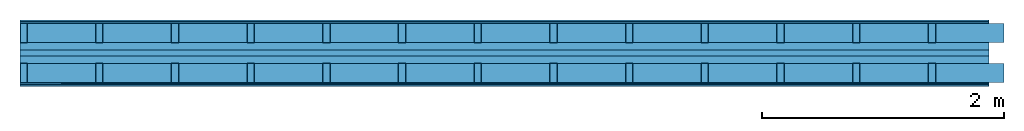
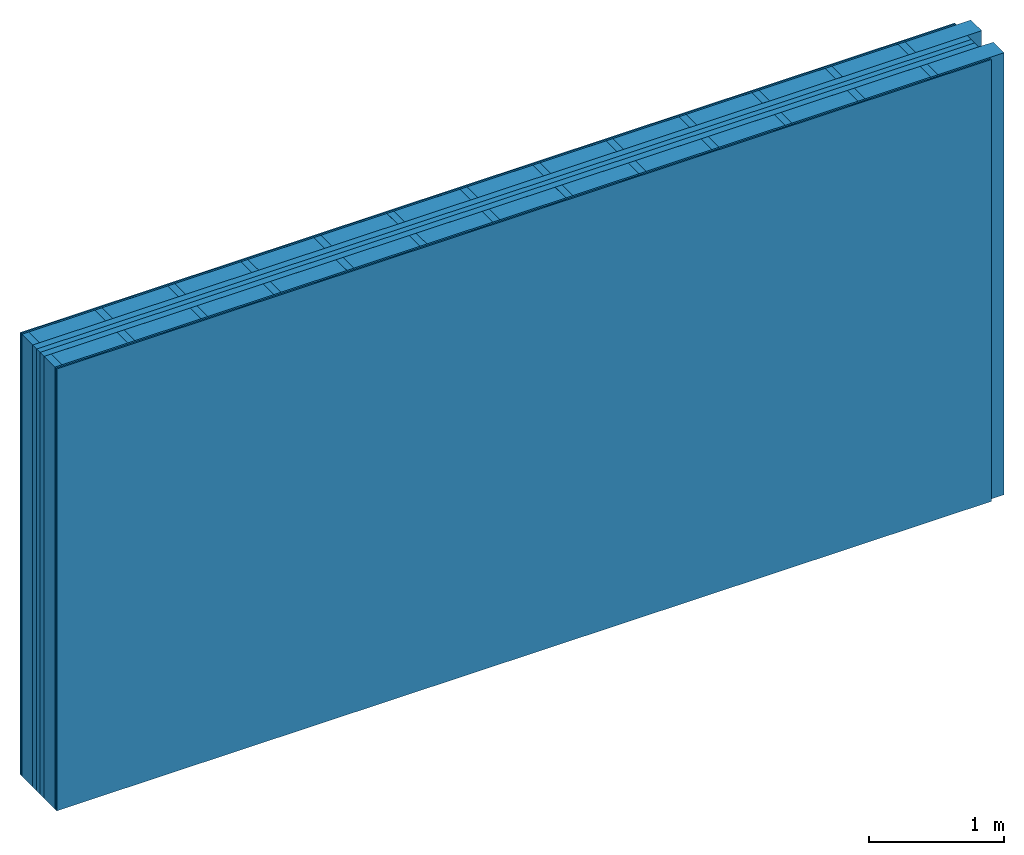
# One storey: 7 plates, 4 members, 1 element without a shape of its own.
"""IFC4 building model written with IfcOpenShell, lengths in metres."""

from ifc_helpers import new_model, si_unit, derived_unit, direction, frame, frame_2d, origin, origin_with_axes, place, context, project, spatial, rectangle, extrude, material, layer, layer_set, type_object, element, aggregate, save


model = new_model("IFC4")

# Units and contexts
plan_context = context("Plan", 3, precision=1e-05, world=origin(), true_north=direction((0.0, 1.0)))
model_context = context("Model", 3, precision=1e-05, world=origin(), true_north=direction((0.0, 1.0)))
ifc_project = project(units=[si_unit("LENGTHUNIT", "METRE"), derived_unit("SOUNDPRESSUREUNIT", [(si_unit("PRESSUREUNIT", "PASCAL", prefix="MICRO"), 0)]), si_unit("ENERGYUNIT", "JOULE", prefix="MEGA"), si_unit("MASSUNIT", "GRAM", prefix="KILO"), derived_unit("THERMALTRANSMITTANCEUNIT", [(si_unit("POWERUNIT", "WATT"), 1), (si_unit("AREAUNIT", "SQUARE_METRE"), -1), (si_unit("THERMODYNAMICTEMPERATUREUNIT", "KELVIN"), -1)]), derived_unit("AREADENSITYUNIT", [(si_unit("MASSUNIT", "GRAM", prefix="KILO"), 1), (si_unit("AREAUNIT", "SQUARE_METRE"), -1)]), derived_unit("USERDEFINED", [(si_unit("ENERGYUNIT", "JOULE", prefix="MEGA"), 1), (si_unit("AREAUNIT", "SQUARE_METRE"), -1)])], contexts=[plan_context, model_context])

# Site, building, storey
site = spatial("IfcSite", under=ifc_project)
building_placement = place(None, origin())
building = spatial("IfcBuilding", under=site, at=building_placement)
storey_placement = place(building_placement, origin())
storey = spatial("IfcBuildingStorey", under=building, at=storey_placement)

# Wall, members, plates
ifc_material_1 = material(Name="Glued joints")
ifc_layer_1 = layer(ifc_material_1, 0.0, Name="Surface")
ifc_material_2 = material(Category="03.007")
ifc_layer_2 = layer(ifc_material_2, 0.0125, Name="room side 2nd layer")
ifc_material_3 = material(Name="OSB/3", Category="07.013")
ifc_layer_3 = layer(ifc_material_3, 0.015, Name="room side 1st layer")
ifc_layer_4 = layer(None, 0.16, Name="Support")
ifc_material_4 = material(Name="of the art")
ifc_layer_5 = layer(ifc_material_4, 0.0, Name="Bond")
ifc_material_5 = material(Category="10.009")
ifc_layer_6 = layer(ifc_material_5, 0.06, Name="outside 1st layer")
ifc_material_6 = material(Name="Air")
ifc_layer_7 = layer(ifc_material_6, 0.05, Name="Air gap")
ifc_layer_8 = layer(ifc_material_5, 0.06, Name="outside 1st layer")
ifc_layer_9 = layer(ifc_material_4, 0.0, Name="Bond")
ifc_layer_10 = layer(None, 0.16, Name="Support")
ifc_layer_11 = layer(ifc_material_3, 0.015, Name="room side 1st layer")
ifc_layer_12 = layer(ifc_material_2, 0.0125, Name="room side 2nd layer")
ifc_layer_set = layer_set([ifc_layer_1, ifc_layer_2, ifc_layer_3, ifc_layer_4, ifc_layer_5, ifc_layer_6, ifc_layer_7, ifc_layer_8, ifc_layer_9, ifc_layer_10, ifc_layer_11, ifc_layer_12])
wall_type = type_object("IfcWallType", Name="B9398", PredefinedType="NOTDEFINED", material=ifc_layer_set)
wall_placement = place(None, frame((0.0, 0.0, 0.0), z_axis=(0.0, -1.0, 0.0), x_axis=(1.0, 0.0, 0.0)))
wall = element("IfcWall", 1, at=wall_placement, inside=storey, type_object=wall_type, material=ifc_layer_set, Name="Wall #1")
ifc_material_7 = material()
member_1_placement = place(wall_placement, origin())
member_1 = element("IfcMember", 2, at=member_1_placement, material=ifc_material_7, Name="Support", context=plan_context, shape_type="SweptSolid", body=[
    extrude(rectangle(XDim=0.06, YDim=0.16, at=frame_2d((0.03, 0.08), x_axis=(1.0, 0.0))), frame((0.0, 4.0, 0.0275), z_axis=(0.0, -1.0, 0.0), x_axis=(1.0, 0.0, 0.0)), (0.0, 0.0, 1.0), 4.0),
    extrude(rectangle(XDim=0.06, YDim=0.16, at=frame_2d((0.03, 0.08), x_axis=(1.0, 0.0))), frame((0.625, 4.0, 0.0275), z_axis=(0.0, -1.0, 0.0), x_axis=(1.0, 0.0, 0.0)), (0.0, 0.0, 1.0), 4.0),
    extrude(rectangle(XDim=0.06, YDim=0.16, at=frame_2d((0.03, 0.08), x_axis=(1.0, 0.0))), frame((1.25, 4.0, 0.0275), z_axis=(0.0, -1.0, 0.0), x_axis=(1.0, 0.0, 0.0)), (0.0, 0.0, 1.0), 4.0),
    extrude(rectangle(XDim=0.06, YDim=0.16, at=frame_2d((0.03, 0.08), x_axis=(1.0, 0.0))), frame((1.875, 4.0, 0.0275), z_axis=(0.0, -1.0, 0.0), x_axis=(1.0, 0.0, 0.0)), (0.0, 0.0, 1.0), 4.0),
    extrude(rectangle(XDim=0.06, YDim=0.16, at=frame_2d((0.03, 0.08), x_axis=(1.0, 0.0))), frame((2.5, 4.0, 0.0275), z_axis=(0.0, -1.0, 0.0), x_axis=(1.0, 0.0, 0.0)), (0.0, 0.0, 1.0), 4.0),
    extrude(rectangle(XDim=0.06, YDim=0.16, at=frame_2d((0.03, 0.08), x_axis=(1.0, 0.0))), frame((3.125, 4.0, 0.0275), z_axis=(0.0, -1.0, 0.0), x_axis=(1.0, 0.0, 0.0)), (0.0, 0.0, 1.0), 4.0),
    extrude(rectangle(XDim=0.06, YDim=0.16, at=frame_2d((0.03, 0.08), x_axis=(1.0, 0.0))), frame((3.75, 4.0, 0.0275), z_axis=(0.0, -1.0, 0.0), x_axis=(1.0, 0.0, 0.0)), (0.0, 0.0, 1.0), 4.0),
    extrude(rectangle(XDim=0.06, YDim=0.16, at=frame_2d((0.03, 0.08), x_axis=(1.0, 0.0))), frame((4.375, 4.0, 0.0275), z_axis=(0.0, -1.0, 0.0), x_axis=(1.0, 0.0, 0.0)), (0.0, 0.0, 1.0), 4.0),
    extrude(rectangle(XDim=0.06, YDim=0.16, at=frame_2d((0.03, 0.08), x_axis=(1.0, 0.0))), frame((5.0, 4.0, 0.0275), z_axis=(0.0, -1.0, 0.0), x_axis=(1.0, 0.0, 0.0)), (0.0, 0.0, 1.0), 4.0),
    extrude(rectangle(XDim=0.06, YDim=0.16, at=frame_2d((0.03, 0.08), x_axis=(1.0, 0.0))), frame((5.625, 4.0, 0.0275), z_axis=(0.0, -1.0, 0.0), x_axis=(1.0, 0.0, 0.0)), (0.0, 0.0, 1.0), 4.0),
    extrude(rectangle(XDim=0.06, YDim=0.16, at=frame_2d((0.03, 0.08), x_axis=(1.0, 0.0))), frame((6.25, 4.0, 0.0275), z_axis=(0.0, -1.0, 0.0), x_axis=(1.0, 0.0, 0.0)), (0.0, 0.0, 1.0), 4.0),
    extrude(rectangle(XDim=0.06, YDim=0.16, at=frame_2d((0.03, 0.08), x_axis=(1.0, 0.0))), frame((6.875, 4.0, 0.0275), z_axis=(0.0, -1.0, 0.0), x_axis=(1.0, 0.0, 0.0)), (0.0, 0.0, 1.0), 4.0),
    extrude(rectangle(XDim=0.06, YDim=0.16, at=frame_2d((0.03, 0.08), x_axis=(1.0, 0.0))), frame((7.5, 4.0, 0.0275), z_axis=(0.0, -1.0, 0.0), x_axis=(1.0, 0.0, 0.0)), (0.0, 0.0, 1.0), 4.0),
])
ifc_material_8 = material()
member_2_placement = place(wall_placement, origin())
member_2 = element("IfcMember", 3, at=member_2_placement, material=ifc_material_8, Name="Cavity", context=plan_context, shape_type="SweptSolid", body=[
    extrude(rectangle(XDim=0.565, YDim=0.16, at=frame_2d((0.2825, 0.08), x_axis=(1.0, 0.0))), frame((0.06, 4.0, 0.0275), z_axis=(0.0, -1.0, 0.0), x_axis=(1.0, 0.0, 0.0)), (0.0, 0.0, 1.0), 4.0),
    extrude(rectangle(XDim=0.565, YDim=0.16, at=frame_2d((0.2825, 0.08), x_axis=(1.0, 0.0))), frame((0.685, 4.0, 0.0275), z_axis=(0.0, -1.0, 0.0), x_axis=(1.0, 0.0, 0.0)), (0.0, 0.0, 1.0), 4.0),
    extrude(rectangle(XDim=0.565, YDim=0.16, at=frame_2d((0.2825, 0.08), x_axis=(1.0, 0.0))), frame((1.31, 4.0, 0.0275), z_axis=(0.0, -1.0, 0.0), x_axis=(1.0, 0.0, 0.0)), (0.0, 0.0, 1.0), 4.0),
    extrude(rectangle(XDim=0.565, YDim=0.16, at=frame_2d((0.2825, 0.08), x_axis=(1.0, 0.0))), frame((1.935, 4.0, 0.0275), z_axis=(0.0, -1.0, 0.0), x_axis=(1.0, 0.0, 0.0)), (0.0, 0.0, 1.0), 4.0),
    extrude(rectangle(XDim=0.565, YDim=0.16, at=frame_2d((0.2825, 0.08), x_axis=(1.0, 0.0))), frame((2.56, 4.0, 0.0275), z_axis=(0.0, -1.0, 0.0), x_axis=(1.0, 0.0, 0.0)), (0.0, 0.0, 1.0), 4.0),
    extrude(rectangle(XDim=0.565, YDim=0.16, at=frame_2d((0.2825, 0.08), x_axis=(1.0, 0.0))), frame((3.185, 4.0, 0.0275), z_axis=(0.0, -1.0, 0.0), x_axis=(1.0, 0.0, 0.0)), (0.0, 0.0, 1.0), 4.0),
    extrude(rectangle(XDim=0.565, YDim=0.16, at=frame_2d((0.2825, 0.08), x_axis=(1.0, 0.0))), frame((3.81, 4.0, 0.0275), z_axis=(0.0, -1.0, 0.0), x_axis=(1.0, 0.0, 0.0)), (0.0, 0.0, 1.0), 4.0),
    extrude(rectangle(XDim=0.565, YDim=0.16, at=frame_2d((0.2825, 0.08), x_axis=(1.0, 0.0))), frame((4.435, 4.0, 0.0275), z_axis=(0.0, -1.0, 0.0), x_axis=(1.0, 0.0, 0.0)), (0.0, 0.0, 1.0), 4.0),
    extrude(rectangle(XDim=0.565, YDim=0.16, at=frame_2d((0.2825, 0.08), x_axis=(1.0, 0.0))), frame((5.06, 4.0, 0.0275), z_axis=(0.0, -1.0, 0.0), x_axis=(1.0, 0.0, 0.0)), (0.0, 0.0, 1.0), 4.0),
    extrude(rectangle(XDim=0.565, YDim=0.16, at=frame_2d((0.2825, 0.08), x_axis=(1.0, 0.0))), frame((5.685, 4.0, 0.0275), z_axis=(0.0, -1.0, 0.0), x_axis=(1.0, 0.0, 0.0)), (0.0, 0.0, 1.0), 4.0),
    extrude(rectangle(XDim=0.565, YDim=0.16, at=frame_2d((0.2825, 0.08), x_axis=(1.0, 0.0))), frame((6.31, 4.0, 0.0275), z_axis=(0.0, -1.0, 0.0), x_axis=(1.0, 0.0, 0.0)), (0.0, 0.0, 1.0), 4.0),
    extrude(rectangle(XDim=0.565, YDim=0.16, at=frame_2d((0.2825, 0.08), x_axis=(1.0, 0.0))), frame((6.935, 4.0, 0.0275), z_axis=(0.0, -1.0, 0.0), x_axis=(1.0, 0.0, 0.0)), (0.0, 0.0, 1.0), 4.0),
    extrude(rectangle(XDim=0.565, YDim=0.16, at=frame_2d((0.2825, 0.08), x_axis=(1.0, 0.0))), frame((7.56, 4.0, 0.0275), z_axis=(0.0, -1.0, 0.0), x_axis=(1.0, 0.0, 0.0)), (0.0, 0.0, 1.0), 4.0),
])
member_3_placement = place(wall_placement, origin())
member_3 = element("IfcMember", 4, at=member_3_placement, material=ifc_material_7, Name="Support", context=plan_context, shape_type="SweptSolid", body=[
    extrude(rectangle(XDim=0.06, YDim=0.16, at=frame_2d((0.03, 0.08), x_axis=(1.0, 0.0))), frame((0.0, 4.0, 0.3575), z_axis=(0.0, -1.0, 0.0), x_axis=(1.0, 0.0, 0.0)), (0.0, 0.0, 1.0), 4.0),
    extrude(rectangle(XDim=0.06, YDim=0.16, at=frame_2d((0.03, 0.08), x_axis=(1.0, 0.0))), frame((0.625, 4.0, 0.3575), z_axis=(0.0, -1.0, 0.0), x_axis=(1.0, 0.0, 0.0)), (0.0, 0.0, 1.0), 4.0),
    extrude(rectangle(XDim=0.06, YDim=0.16, at=frame_2d((0.03, 0.08), x_axis=(1.0, 0.0))), frame((1.25, 4.0, 0.3575), z_axis=(0.0, -1.0, 0.0), x_axis=(1.0, 0.0, 0.0)), (0.0, 0.0, 1.0), 4.0),
    extrude(rectangle(XDim=0.06, YDim=0.16, at=frame_2d((0.03, 0.08), x_axis=(1.0, 0.0))), frame((1.875, 4.0, 0.3575), z_axis=(0.0, -1.0, 0.0), x_axis=(1.0, 0.0, 0.0)), (0.0, 0.0, 1.0), 4.0),
    extrude(rectangle(XDim=0.06, YDim=0.16, at=frame_2d((0.03, 0.08), x_axis=(1.0, 0.0))), frame((2.5, 4.0, 0.3575), z_axis=(0.0, -1.0, 0.0), x_axis=(1.0, 0.0, 0.0)), (0.0, 0.0, 1.0), 4.0),
    extrude(rectangle(XDim=0.06, YDim=0.16, at=frame_2d((0.03, 0.08), x_axis=(1.0, 0.0))), frame((3.125, 4.0, 0.3575), z_axis=(0.0, -1.0, 0.0), x_axis=(1.0, 0.0, 0.0)), (0.0, 0.0, 1.0), 4.0),
    extrude(rectangle(XDim=0.06, YDim=0.16, at=frame_2d((0.03, 0.08), x_axis=(1.0, 0.0))), frame((3.75, 4.0, 0.3575), z_axis=(0.0, -1.0, 0.0), x_axis=(1.0, 0.0, 0.0)), (0.0, 0.0, 1.0), 4.0),
    extrude(rectangle(XDim=0.06, YDim=0.16, at=frame_2d((0.03, 0.08), x_axis=(1.0, 0.0))), frame((4.375, 4.0, 0.3575), z_axis=(0.0, -1.0, 0.0), x_axis=(1.0, 0.0, 0.0)), (0.0, 0.0, 1.0), 4.0),
    extrude(rectangle(XDim=0.06, YDim=0.16, at=frame_2d((0.03, 0.08), x_axis=(1.0, 0.0))), frame((5.0, 4.0, 0.3575), z_axis=(0.0, -1.0, 0.0), x_axis=(1.0, 0.0, 0.0)), (0.0, 0.0, 1.0), 4.0),
    extrude(rectangle(XDim=0.06, YDim=0.16, at=frame_2d((0.03, 0.08), x_axis=(1.0, 0.0))), frame((5.625, 4.0, 0.3575), z_axis=(0.0, -1.0, 0.0), x_axis=(1.0, 0.0, 0.0)), (0.0, 0.0, 1.0), 4.0),
    extrude(rectangle(XDim=0.06, YDim=0.16, at=frame_2d((0.03, 0.08), x_axis=(1.0, 0.0))), frame((6.25, 4.0, 0.3575), z_axis=(0.0, -1.0, 0.0), x_axis=(1.0, 0.0, 0.0)), (0.0, 0.0, 1.0), 4.0),
    extrude(rectangle(XDim=0.06, YDim=0.16, at=frame_2d((0.03, 0.08), x_axis=(1.0, 0.0))), frame((6.875, 4.0, 0.3575), z_axis=(0.0, -1.0, 0.0), x_axis=(1.0, 0.0, 0.0)), (0.0, 0.0, 1.0), 4.0),
    extrude(rectangle(XDim=0.06, YDim=0.16, at=frame_2d((0.03, 0.08), x_axis=(1.0, 0.0))), frame((7.5, 4.0, 0.3575), z_axis=(0.0, -1.0, 0.0), x_axis=(1.0, 0.0, 0.0)), (0.0, 0.0, 1.0), 4.0),
])
member_4_placement = place(wall_placement, origin())
member_4 = element("IfcMember", 5, at=member_4_placement, material=ifc_material_8, Name="Cavity", context=plan_context, shape_type="SweptSolid", body=[
    extrude(rectangle(XDim=0.565, YDim=0.16, at=frame_2d((0.2825, 0.08), x_axis=(1.0, 0.0))), frame((0.06, 4.0, 0.3575), z_axis=(0.0, -1.0, 0.0), x_axis=(1.0, 0.0, 0.0)), (0.0, 0.0, 1.0), 4.0),
    extrude(rectangle(XDim=0.565, YDim=0.16, at=frame_2d((0.2825, 0.08), x_axis=(1.0, 0.0))), frame((0.685, 4.0, 0.3575), z_axis=(0.0, -1.0, 0.0), x_axis=(1.0, 0.0, 0.0)), (0.0, 0.0, 1.0), 4.0),
    extrude(rectangle(XDim=0.565, YDim=0.16, at=frame_2d((0.2825, 0.08), x_axis=(1.0, 0.0))), frame((1.31, 4.0, 0.3575), z_axis=(0.0, -1.0, 0.0), x_axis=(1.0, 0.0, 0.0)), (0.0, 0.0, 1.0), 4.0),
    extrude(rectangle(XDim=0.565, YDim=0.16, at=frame_2d((0.2825, 0.08), x_axis=(1.0, 0.0))), frame((1.935, 4.0, 0.3575), z_axis=(0.0, -1.0, 0.0), x_axis=(1.0, 0.0, 0.0)), (0.0, 0.0, 1.0), 4.0),
    extrude(rectangle(XDim=0.565, YDim=0.16, at=frame_2d((0.2825, 0.08), x_axis=(1.0, 0.0))), frame((2.56, 4.0, 0.3575), z_axis=(0.0, -1.0, 0.0), x_axis=(1.0, 0.0, 0.0)), (0.0, 0.0, 1.0), 4.0),
    extrude(rectangle(XDim=0.565, YDim=0.16, at=frame_2d((0.2825, 0.08), x_axis=(1.0, 0.0))), frame((3.185, 4.0, 0.3575), z_axis=(0.0, -1.0, 0.0), x_axis=(1.0, 0.0, 0.0)), (0.0, 0.0, 1.0), 4.0),
    extrude(rectangle(XDim=0.565, YDim=0.16, at=frame_2d((0.2825, 0.08), x_axis=(1.0, 0.0))), frame((3.81, 4.0, 0.3575), z_axis=(0.0, -1.0, 0.0), x_axis=(1.0, 0.0, 0.0)), (0.0, 0.0, 1.0), 4.0),
    extrude(rectangle(XDim=0.565, YDim=0.16, at=frame_2d((0.2825, 0.08), x_axis=(1.0, 0.0))), frame((4.435, 4.0, 0.3575), z_axis=(0.0, -1.0, 0.0), x_axis=(1.0, 0.0, 0.0)), (0.0, 0.0, 1.0), 4.0),
    extrude(rectangle(XDim=0.565, YDim=0.16, at=frame_2d((0.2825, 0.08), x_axis=(1.0, 0.0))), frame((5.06, 4.0, 0.3575), z_axis=(0.0, -1.0, 0.0), x_axis=(1.0, 0.0, 0.0)), (0.0, 0.0, 1.0), 4.0),
    extrude(rectangle(XDim=0.565, YDim=0.16, at=frame_2d((0.2825, 0.08), x_axis=(1.0, 0.0))), frame((5.685, 4.0, 0.3575), z_axis=(0.0, -1.0, 0.0), x_axis=(1.0, 0.0, 0.0)), (0.0, 0.0, 1.0), 4.0),
    extrude(rectangle(XDim=0.565, YDim=0.16, at=frame_2d((0.2825, 0.08), x_axis=(1.0, 0.0))), frame((6.31, 4.0, 0.3575), z_axis=(0.0, -1.0, 0.0), x_axis=(1.0, 0.0, 0.0)), (0.0, 0.0, 1.0), 4.0),
    extrude(rectangle(XDim=0.565, YDim=0.16, at=frame_2d((0.2825, 0.08), x_axis=(1.0, 0.0))), frame((6.935, 4.0, 0.3575), z_axis=(0.0, -1.0, 0.0), x_axis=(1.0, 0.0, 0.0)), (0.0, 0.0, 1.0), 4.0),
    extrude(rectangle(XDim=0.565, YDim=0.16, at=frame_2d((0.2825, 0.08), x_axis=(1.0, 0.0))), frame((7.56, 4.0, 0.3575), z_axis=(0.0, -1.0, 0.0), x_axis=(1.0, 0.0, 0.0)), (0.0, 0.0, 1.0), 4.0),
])
plate_1_placement = place(wall_placement, origin())
plate_1 = element("IfcPlate", 6, at=plate_1_placement, material=ifc_material_2, Name="room side 2nd layer", context=plan_context, shape_type="SweptSolid", body=[
    extrude(rectangle(XDim=8.0, YDim=4.0, at=frame_2d((4.0, 2.0), x_axis=(1.0, 0.0))), origin_with_axes(), (0.0, 0.0, 1.0), 0.0125),
])
plate_2_placement = place(wall_placement, origin())
plate_2 = element("IfcPlate", 7, at=plate_2_placement, material=ifc_material_3, Name="room side 1st layer", context=plan_context, shape_type="SweptSolid", body=[
    extrude(rectangle(XDim=8.0, YDim=4.0, at=frame_2d((4.0, 2.0), x_axis=(1.0, 0.0))), frame((0.0, 0.0, 0.0125), z_axis=(0.0, 0.0, 1.0), x_axis=(1.0, 0.0, 0.0)), (0.0, 0.0, 1.0), 0.015),
])
plate_3_placement = place(wall_placement, origin())
plate_3 = element("IfcPlate", 8, at=plate_3_placement, material=ifc_material_5, Name="outside 1st layer", context=plan_context, shape_type="SweptSolid", body=[
    extrude(rectangle(XDim=8.0, YDim=4.0, at=frame_2d((4.0, 2.0), x_axis=(1.0, 0.0))), frame((0.0, 0.0, 0.1875), z_axis=(0.0, 0.0, 1.0), x_axis=(1.0, 0.0, 0.0)), (0.0, 0.0, 1.0), 0.06),
])
plate_4_placement = place(wall_placement, origin())
plate_4 = element("IfcPlate", 9, at=plate_4_placement, material=ifc_material_6, Name="Air gap", context=plan_context, shape_type="SweptSolid", body=[
    extrude(rectangle(XDim=8.0, YDim=4.0, at=frame_2d((4.0, 2.0), x_axis=(1.0, 0.0))), frame((0.0, 0.0, 0.2475), z_axis=(0.0, 0.0, 1.0), x_axis=(1.0, 0.0, 0.0)), (0.0, 0.0, 1.0), 0.05),
])
plate_5_placement = place(wall_placement, origin())
plate_5 = element("IfcPlate", 10, at=plate_5_placement, material=ifc_material_5, Name="outside 1st layer", context=plan_context, shape_type="SweptSolid", body=[
    extrude(rectangle(XDim=8.0, YDim=4.0, at=frame_2d((4.0, 2.0), x_axis=(1.0, 0.0))), frame((0.0, 0.0, 0.2975), z_axis=(0.0, 0.0, 1.0), x_axis=(1.0, 0.0, 0.0)), (0.0, 0.0, 1.0), 0.06),
])
plate_6_placement = place(wall_placement, origin())
plate_6 = element("IfcPlate", 11, at=plate_6_placement, material=ifc_material_3, Name="room side 1st layer", context=plan_context, shape_type="SweptSolid", body=[
    extrude(rectangle(XDim=8.0, YDim=4.0, at=frame_2d((4.0, 2.0), x_axis=(1.0, 0.0))), frame((0.0, 0.0, 0.5175), z_axis=(0.0, 0.0, 1.0), x_axis=(1.0, 0.0, 0.0)), (0.0, 0.0, 1.0), 0.015),
])
plate_7_placement = place(wall_placement, origin())
plate_7 = element("IfcPlate", 12, at=plate_7_placement, material=ifc_material_2, Name="room side 2nd layer", context=plan_context, shape_type="SweptSolid", body=[
    extrude(rectangle(XDim=8.0, YDim=4.0, at=frame_2d((4.0, 2.0), x_axis=(1.0, 0.0))), frame((0.0, 0.0, 0.5325), z_axis=(0.0, 0.0, 1.0), x_axis=(1.0, 0.0, 0.0)), (0.0, 0.0, 1.0), 0.0125),
])
aggregate(wall, [plate_1, plate_2, member_1, member_2, plate_3, plate_4, plate_5, member_3, member_4, plate_6, plate_7])

save(model, "model.ifc")
